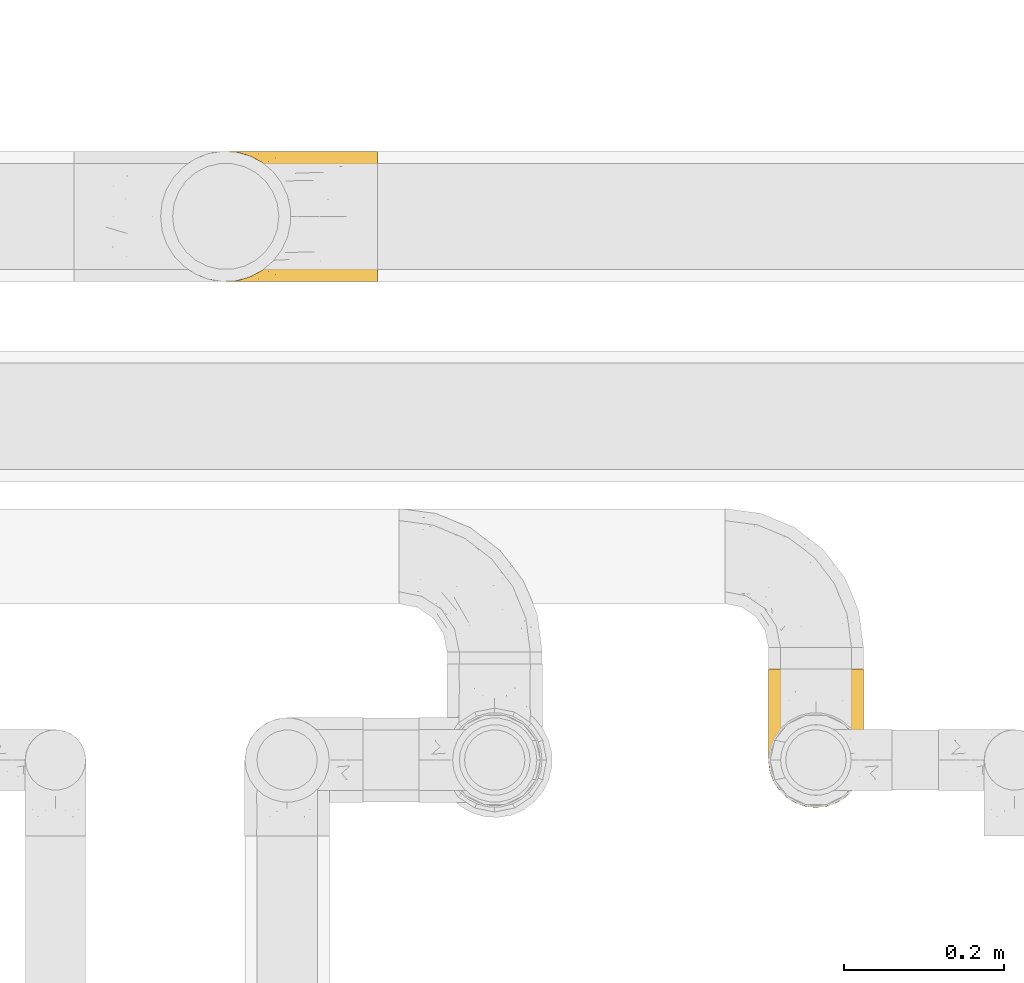
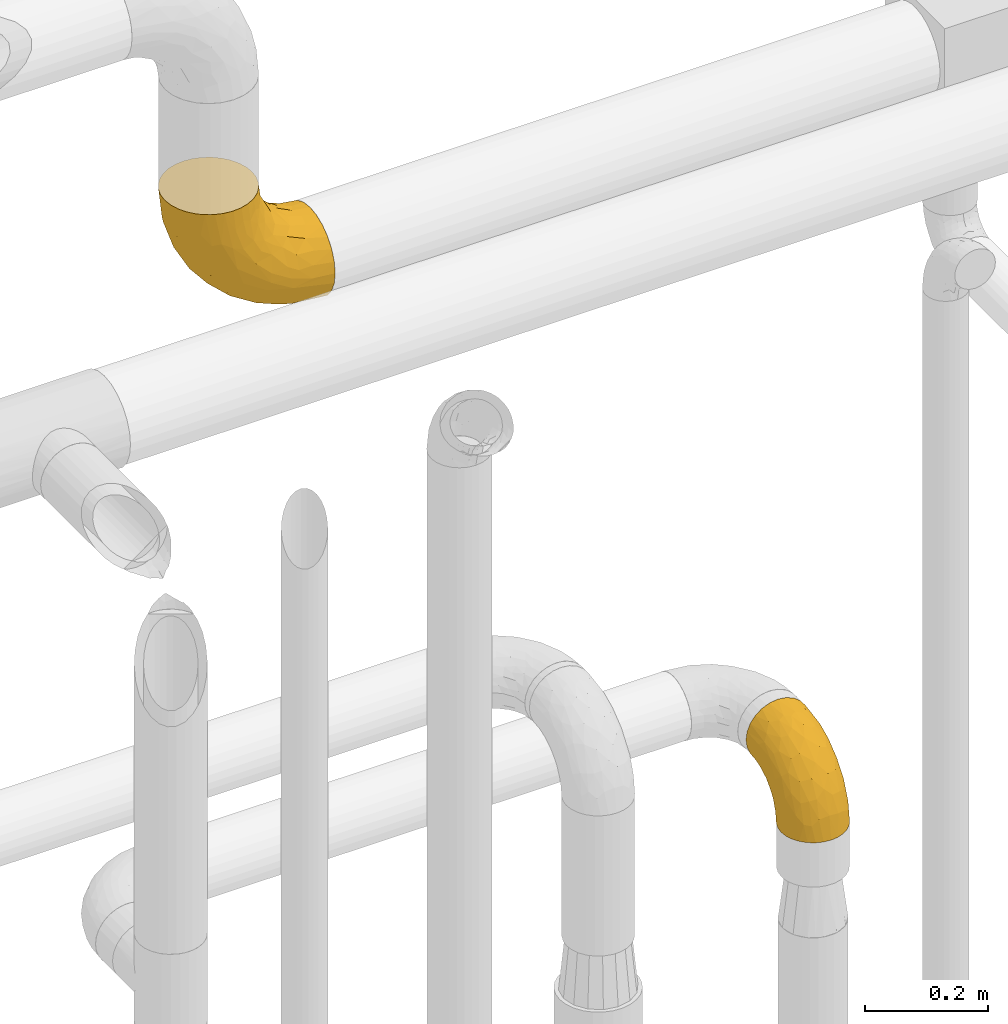
# One storey, part 474 of 827: 2 coverings.
"""IFC2X3 building model written with IfcOpenShell, lengths in millimetres."""

from ifc_helpers import new_model, entity, si_unit, converted_unit, derived_unit, direction, frame, origin, place, context, subcontext, project, spatial, faceted_brep, element, save


model = new_model("IFC2X3")

# Units and contexts
model_context = context("Model", 3, precision=0.01, world=origin(), true_north=direction((6.12303176911189e-17, 1.0)))
body_context = subcontext(model_context, "Body", "Model", "MODEL_VIEW")
ifc_project = project(units=[si_unit("LENGTHUNIT", "METRE", prefix="MILLI"), si_unit("AREAUNIT", "SQUARE_METRE"), si_unit("VOLUMEUNIT", "CUBIC_METRE"), converted_unit("PLANEANGLEUNIT", "DEGREE", entity("IfcRatioMeasure", 0.0174532925199433), si_unit("PLANEANGLEUNIT", "RADIAN"), dimensions=[0, 0, 0, 0, 0, 0, 0]), si_unit("MASSUNIT", "GRAM", prefix="KILO"), derived_unit("MASSDENSITYUNIT", [(si_unit("MASSUNIT", "GRAM", prefix="KILO"), 1), (si_unit("LENGTHUNIT", "METRE"), -3)]), derived_unit("MOMENTOFINERTIAUNIT", [(si_unit("LENGTHUNIT", "METRE"), 4)]), si_unit("TIMEUNIT", "SECOND"), si_unit("FREQUENCYUNIT", "HERTZ"), si_unit("THERMODYNAMICTEMPERATUREUNIT", "DEGREE_CELSIUS"), derived_unit("THERMALTRANSMITTANCEUNIT", [(si_unit("MASSUNIT", "GRAM", prefix="KILO"), 1), (si_unit("THERMODYNAMICTEMPERATUREUNIT", "KELVIN"), -1), (si_unit("TIMEUNIT", "SECOND"), -3)]), derived_unit("VOLUMETRICFLOWRATEUNIT", [(si_unit("LENGTHUNIT", "METRE"), 3), (si_unit("TIMEUNIT", "SECOND"), -1)]), derived_unit("MASSFLOWRATEUNIT", [(si_unit("MASSUNIT", "GRAM", prefix="KILO"), 1), (si_unit("TIMEUNIT", "SECOND"), -1)]), derived_unit("ROTATIONALFREQUENCYUNIT", [(si_unit("TIMEUNIT", "SECOND"), -1)]), si_unit("ELECTRICCURRENTUNIT", "AMPERE"), si_unit("ELECTRICVOLTAGEUNIT", "VOLT"), si_unit("POWERUNIT", "WATT"), si_unit("FORCEUNIT", "NEWTON", prefix="KILO"), si_unit("ILLUMINANCEUNIT", "LUX"), si_unit("LUMINOUSFLUXUNIT", "LUMEN"), si_unit("LUMINOUSINTENSITYUNIT", "CANDELA"), derived_unit("USERDEFINED", [(si_unit("MASSUNIT", "GRAM", prefix="KILO"), -1), (si_unit("LENGTHUNIT", "METRE"), -2), (si_unit("TIMEUNIT", "SECOND"), 3), (si_unit("LUMINOUSFLUXUNIT", "LUMEN"), 1)]), derived_unit("LINEARVELOCITYUNIT", [(si_unit("LENGTHUNIT", "METRE"), 1), (si_unit("TIMEUNIT", "SECOND"), -1)]), si_unit("PRESSUREUNIT", "PASCAL"), derived_unit("USERDEFINED", [(si_unit("LENGTHUNIT", "METRE"), -2), (si_unit("MASSUNIT", "GRAM", prefix="KILO"), 1), (si_unit("TIMEUNIT", "SECOND"), -2)]), derived_unit("LINEARFORCEUNIT", [(si_unit("MASSUNIT", "GRAM", prefix="KILO"), 1), (si_unit("LENGTHUNIT", "METRE"), 1), (si_unit("TIMEUNIT", "SECOND"), -2), (si_unit("LENGTHUNIT", "METRE"), -1)]), derived_unit("PLANARFORCEUNIT", [(si_unit("MASSUNIT", "GRAM", prefix="KILO"), 1), (si_unit("LENGTHUNIT", "METRE"), 1), (si_unit("TIMEUNIT", "SECOND"), -2), (si_unit("LENGTHUNIT", "METRE"), -2)])], contexts=[model_context])

# Site, building, storey
site_placement = place(None, origin())
site = spatial("IfcSite", under=ifc_project, at=site_placement, CompositionType="ELEMENT")
building_placement = place(site_placement, origin())
building = spatial("IfcBuilding", under=site, at=building_placement, CompositionType="ELEMENT")
storey_placement = place(building_placement, frame((0.0, 0.0, 28200.0)))
storey = spatial("IfcBuildingStorey", under=building, at=storey_placement, Name="08", CompositionType="ELEMENT", Elevation=28200.0)

# Coverings
covering_1_placement = place(storey_placement, frame((58588.34, 17438.95, 1984.4)))
element("IfcCovering", 1, at=covering_1_placement, inside=storey, Name=":ADSK_", ObjectType=":ADSK_", PredefinedType="INSULATION", context=body_context, shape_type="Brep", body=[
    faceted_brep([(119.0, 47.81, 1.6), (114.61, 35.25, 1.6), (107.52, 23.97, 1.6), (98.11, 14.56, 1.6), (86.83, 7.48, 1.6), (74.26, 3.08, 1.6), (61.05, 1.6, 1.6), (47.81, 3.09, 1.6), (35.25, 7.48, 1.6), (23.97, 14.57, 1.6), (14.56, 23.99, 1.6), (7.48, 35.26, 1.6), (3.08, 47.83, 1.6), (1.6, 61.05, 1.6), (3.09, 74.28, 1.6), (7.48, 86.84, 1.6), (14.57, 98.12, 1.6), (23.99, 107.53, 1.6), (35.26, 114.61, 1.6), (47.83, 119.01, 1.6), (61.05, 120.5, 1.6), (74.28, 119.0, 1.6), (86.84, 114.61, 1.6), (98.12, 107.52, 1.6), (107.53, 98.11, 1.6), (114.61, 86.83, 1.6), (119.01, 74.26, 1.6), (120.5, 61.05, 1.6), (45.66, 175.05, 58.17), (31.32, 175.05, 64.11), (19.01, 175.05, 73.56), (9.56, 175.05, 85.87), (3.62, 175.05, 100.21), (1.6, 175.05, 115.6), (3.62, 175.05, 130.98), (9.56, 175.05, 145.32), (19.01, 175.05, 157.63), (31.32, 175.05, 167.08), (45.66, 175.05, 173.02), (61.05, 175.05, 175.05), (76.43, 175.05, 173.02), (90.77, 175.05, 167.08), (103.08, 175.05, 157.63), (112.53, 175.05, 145.32), (118.47, 175.05, 130.98), (120.5, 175.05, 115.6), (118.47, 175.05, 100.21), (112.53, 175.05, 85.87), (103.08, 175.05, 73.56), (90.77, 175.05, 64.11), (76.43, 175.05, 58.17), (61.05, 175.05, 56.15), (95.74, 144.29, 160.93), (82.17, 133.4, 165.97), (93.88, 108.85, 151.16), (71.8, 137.58, 169.95), (61.05, 130.15, 169.14), (109.14, 33.43, 47.74), (108.65, 48.64, 81.62), (100.7, 32.13, 69.65), (79.94, 71.77, 137.09), (61.05, 88.32, 151.81), (61.05, 52.4, 124.24), (115.7, 105.93, 120.32), (112.92, 128.22, 136.76), (110.7, 102.42, 129.05), (117.93, 138.98, 127.83), (119.47, 114.96, 111.19), (89.21, 25.03, 73.49), (91.01, 14.44, 40.92), (83.0, 103.12, 154.8), (71.74, 109.71, 161.22), (106.1, 133.1, 148.51), (61.05, 7.51, 46.49), (79.17, 9.66, 43.55), (76.32, 38.78, 105.65), (73.8, 19.81, 75.81), (112.99, 73.56, 102.22), (104.29, 65.59, 111.05), (119.46, 53.66, 31.64), (119.47, 65.45, 61.68), (115.7, 56.32, 70.72), (120.5, 108.04, 93.82), (120.5, 123.93, 101.92), (120.5, 139.82, 110.02), (61.05, 24.83, 88.32), (115.97, 42.35, 34.61), (101.43, 20.84, 34.27), (94.14, 74.42, 130.32), (94.58, 46.21, 101.6), (104.07, 96.34, 135.16), (118.63, 83.99, 92.65), (120.5, 82.82, 68.6), (120.5, 95.43, 81.21), (120.5, 63.36, 16.21), (120.5, 66.62, 36.82), (120.5, 74.72, 52.71), (120.5, 160.43, 113.28), (117.67, 91.97, 49.51), (114.99, 88.98, 24.29), (109.18, 102.6, 33.37), (118.26, 155.55, 97.47), (117.87, 141.61, 92.13), (111.2, 123.71, 65.64), (103.41, 136.88, 63.0), (108.57, 141.73, 72.44), (112.76, 108.95, 54.52), (75.65, 132.33, 38.38), (89.98, 131.77, 46.09), (85.51, 122.46, 30.11), (61.05, 124.65, 22.47), (73.87, 123.29, 22.86), (111.26, 158.35, 82.06), (101.69, 153.2, 68.74), (88.74, 147.72, 56.57), (86.0, 162.85, 60.39), (74.52, 158.54, 55.21), (70.92, 144.02, 47.46), (61.05, 154.17, 51.99), (118.96, 76.05, 19.27), (119.01, 98.34, 66.98), (117.67, 113.97, 75.5), (82.93, 117.88, 15.03), (96.71, 111.71, 21.65), (96.25, 120.52, 38.96), (106.01, 101.36, 16.17), (119.26, 79.3, 36.61), (105.56, 112.64, 42.47), (61.05, 136.47, 40.17), (114.42, 138.23, 81.33), (119.14, 124.93, 89.72), (102.94, 123.97, 52.09), (18.7, 136.9, 62.98), (19.16, 123.98, 52.08), (10.9, 123.74, 65.65), (5.81, 148.89, 89.82), (2.95, 124.93, 89.72), (2.72, 138.07, 97.2), (46.46, 132.31, 38.35), (9.34, 108.96, 54.51), (1.6, 82.82, 68.6), (1.6, 95.43, 81.21), (3.08, 98.34, 66.99), (47.58, 158.54, 55.21), (7.11, 88.99, 24.29), (36.09, 162.86, 60.39), (16.09, 101.37, 16.17), (25.4, 111.72, 21.63), (3.83, 155.55, 97.47), (1.6, 160.43, 113.28), (4.42, 113.97, 75.5), (20.4, 153.21, 68.74), (51.15, 144.01, 47.46), (10.83, 158.35, 82.06), (16.53, 112.65, 42.47), (25.84, 120.51, 38.93), (48.24, 123.29, 22.84), (1.6, 66.62, 36.82), (1.6, 74.72, 52.71), (2.83, 79.32, 36.62), (1.6, 63.36, 16.21), (36.6, 122.45, 30.08), (39.17, 117.88, 15.02), (32.11, 131.76, 46.08), (33.35, 147.73, 56.57), (1.6, 123.93, 101.92), (4.42, 91.99, 49.52), (12.92, 102.61, 33.36), (3.14, 76.07, 19.28), (13.52, 141.72, 72.43), (1.6, 108.04, 93.82), (1.6, 139.82, 110.02), (7.67, 138.23, 81.33), (28.21, 108.85, 151.16), (26.35, 144.29, 160.93), (15.99, 133.1, 148.51), (9.17, 128.22, 136.76), (50.29, 137.58, 169.95), (39.92, 133.4, 165.97), (50.35, 109.71, 161.22), (2.62, 114.96, 111.19), (6.39, 56.32, 70.72), (2.63, 53.67, 31.66), (6.11, 42.36, 34.61), (17.8, 65.59, 111.05), (13.43, 48.62, 81.57), (27.5, 46.21, 101.58), (2.62, 65.45, 61.68), (3.46, 83.99, 92.65), (4.16, 138.98, 127.83), (39.09, 103.12, 154.8), (21.38, 32.14, 69.65), (20.65, 20.85, 34.27), (32.87, 25.03, 73.47), (31.06, 12.63, 32.52), (45.77, 38.78, 105.65), (42.15, 71.77, 137.09), (12.94, 33.44, 47.72), (11.39, 102.42, 129.05), (9.11, 73.52, 102.2), (42.91, 9.67, 43.54), (18.03, 96.34, 135.17), (27.95, 74.41, 130.32), (45.01, 20.85, 76.08), (6.39, 105.93, 120.32)], [[[0, 1, 2, 3, 4, 5, 6, 7, 8, 9, 10, 11, 12, 13, 14, 15, 16, 17, 18, 19, 20, 21, 22, 23, 24, 25, 26, 27]], [[28, 29, 30, 31, 32, 33, 34, 35, 36, 37, 38, 39, 40, 41, 42, 43, 44, 45, 46, 47, 48, 49, 50, 51]], [[52, 53, 54]], [[55, 39, 56]], [[57, 58, 59]], [[60, 61, 62]], [[63, 64, 65]], [[66, 63, 67]], [[59, 68, 69]], [[53, 70, 54]], [[41, 40, 53]], [[53, 71, 70]], [[72, 42, 52]], [[42, 41, 52]], [[73, 5, 74]], [[68, 75, 76]], [[43, 72, 64]], [[45, 44, 66]], [[58, 77, 78]], [[79, 80, 81]], [[67, 82, 83, 84]], [[75, 62, 85]], [[1, 0, 86]], [[2, 87, 3]], [[57, 87, 2]], [[42, 72, 43]], [[5, 4, 74]], [[2, 1, 57]], [[69, 3, 87]], [[5, 73, 6]], [[59, 87, 57]], [[66, 64, 63]], [[88, 89, 78]], [[54, 88, 90]], [[75, 60, 62]], [[91, 92, 93, 82]], [[79, 27, 94, 95]], [[76, 73, 74]], [[80, 95, 96, 92]], [[57, 1, 86]], [[56, 71, 55]], [[77, 91, 63]], [[80, 91, 81]], [[67, 91, 82]], [[71, 56, 61]], [[69, 4, 3]], [[74, 69, 68]], [[75, 89, 60]], [[80, 79, 95]], [[81, 57, 86]], [[76, 75, 85]], [[89, 68, 59]], [[58, 57, 81]], [[59, 58, 89]], [[90, 88, 78]], [[75, 68, 89]], [[70, 88, 54]], [[60, 89, 88]], [[77, 58, 81]], [[89, 58, 78]], [[91, 77, 81]], [[77, 63, 65]], [[78, 77, 65]], [[54, 90, 72]], [[91, 80, 92]], [[79, 81, 86]], [[86, 0, 79]], [[27, 79, 0]], [[66, 84, 97, 45]], [[91, 67, 63]], [[84, 66, 67]], [[64, 44, 43]], [[64, 66, 44]], [[65, 72, 90]], [[53, 52, 41]], [[72, 52, 54]], [[72, 65, 64]], [[65, 90, 78]], [[60, 71, 61]], [[55, 71, 53]], [[71, 60, 70]], [[88, 70, 60]], [[53, 40, 55]], [[39, 55, 40]], [[4, 69, 74]], [[59, 69, 87]], [[73, 76, 85]], [[68, 76, 74]], [[98, 99, 100]], [[84, 101, 97]], [[84, 83, 102]], [[97, 101, 46]], [[103, 104, 105]], [[47, 46, 101]], [[106, 98, 100]], [[107, 108, 109]], [[110, 107, 111]], [[112, 48, 47]], [[48, 113, 49]], [[113, 114, 115]], [[116, 51, 50]], [[115, 50, 49]], [[116, 117, 118]], [[119, 95, 94]], [[111, 107, 109]], [[93, 120, 121]], [[122, 123, 22]], [[121, 106, 103]], [[25, 24, 99]], [[114, 113, 104]], [[124, 109, 108]], [[25, 119, 26]], [[27, 26, 94]], [[112, 113, 48]], [[125, 123, 100]], [[24, 125, 99]], [[111, 20, 110]], [[109, 122, 111]], [[119, 94, 26]], [[99, 126, 119]], [[123, 124, 127]], [[117, 107, 128]], [[122, 22, 21]], [[129, 130, 121]], [[123, 23, 22]], [[92, 98, 120]], [[127, 106, 100]], [[23, 125, 24]], [[93, 121, 82]], [[119, 126, 95]], [[21, 20, 111]], [[123, 122, 109]], [[21, 111, 122]], [[107, 110, 128]], [[117, 128, 118]], [[107, 117, 108]], [[104, 108, 114]], [[124, 108, 131]], [[25, 99, 119]], [[96, 126, 98]], [[98, 92, 96]], [[123, 125, 23]], [[99, 125, 100]], [[103, 106, 131]], [[120, 106, 121]], [[83, 82, 130]], [[101, 102, 112]], [[130, 102, 83]], [[121, 130, 82]], [[102, 130, 129]], [[101, 112, 47]], [[112, 129, 105]], [[118, 51, 116]], [[108, 117, 114]], [[115, 116, 50]], [[114, 117, 116]], [[112, 102, 129]], [[102, 101, 84]], [[104, 103, 131]], [[129, 121, 103]], [[104, 131, 108]], [[105, 104, 113]], [[112, 105, 113]], [[103, 105, 129]], [[127, 124, 131]], [[123, 109, 124]], [[106, 127, 131]], [[123, 127, 100]], [[98, 126, 99]], [[95, 126, 96]], [[113, 115, 49]], [[116, 115, 114]], [[46, 45, 97]], [[92, 120, 93]], [[106, 120, 98]], [[132, 133, 134]], [[135, 136, 137]], [[110, 138, 128]], [[139, 134, 133]], [[140, 141, 142]], [[143, 51, 118]], [[16, 15, 144]], [[28, 145, 29]], [[146, 147, 17]], [[144, 146, 16]], [[31, 148, 32]], [[148, 149, 32]], [[139, 142, 150]], [[30, 29, 151]], [[152, 143, 118]], [[31, 30, 153]], [[139, 133, 154]], [[155, 154, 133]], [[110, 156, 138]], [[142, 141, 150]], [[20, 19, 156]], [[157, 158, 159]], [[14, 13, 160]], [[17, 16, 146]], [[161, 162, 147]], [[18, 162, 19]], [[152, 163, 164]], [[137, 136, 165]], [[144, 166, 167]], [[133, 163, 155]], [[144, 167, 146]], [[147, 18, 17]], [[29, 145, 151]], [[128, 138, 152]], [[160, 157, 168]], [[160, 168, 14]], [[14, 168, 15]], [[167, 166, 139]], [[151, 169, 153]], [[162, 156, 19]], [[141, 170, 150]], [[164, 163, 132]], [[147, 162, 18]], [[156, 162, 161]], [[156, 161, 138]], [[156, 110, 20]], [[163, 138, 161]], [[128, 152, 118]], [[155, 163, 161]], [[132, 163, 133]], [[159, 166, 144]], [[144, 15, 168]], [[166, 158, 140]], [[168, 159, 144]], [[147, 146, 167]], [[142, 139, 166]], [[134, 139, 150]], [[135, 31, 153]], [[136, 170, 165]], [[136, 150, 170]], [[148, 137, 171]], [[150, 136, 172]], [[151, 153, 30]], [[136, 135, 172]], [[163, 152, 138]], [[143, 28, 51]], [[152, 164, 143]], [[145, 143, 164]], [[171, 137, 165]], [[137, 148, 135]], [[31, 135, 148]], [[172, 135, 153]], [[150, 172, 134]], [[132, 169, 151]], [[169, 134, 172]], [[164, 132, 151]], [[134, 169, 132]], [[153, 169, 172]], [[161, 147, 155]], [[154, 147, 167]], [[147, 154, 155]], [[139, 154, 167]], [[157, 159, 168]], [[166, 159, 158]], [[143, 145, 28]], [[151, 145, 164]], [[149, 148, 171]], [[149, 33, 32]], [[140, 142, 166]], [[173, 174, 175]], [[35, 34, 176]], [[177, 178, 179]], [[180, 171, 165, 170]], [[181, 182, 183]], [[184, 185, 186]], [[187, 188, 140]], [[189, 33, 149, 171]], [[178, 190, 179]], [[34, 189, 176]], [[39, 38, 177]], [[191, 192, 193]], [[9, 8, 194]], [[174, 178, 37]], [[38, 37, 178]], [[35, 175, 36]], [[195, 62, 196]], [[180, 189, 171]], [[37, 36, 174]], [[183, 11, 197]], [[188, 170, 141, 140]], [[184, 198, 199]], [[8, 7, 200]], [[201, 184, 202]], [[13, 12, 182]], [[181, 185, 199]], [[183, 12, 11]], [[62, 195, 85]], [[202, 184, 186]], [[10, 197, 11]], [[199, 188, 181]], [[194, 8, 200]], [[203, 195, 193]], [[62, 61, 196]], [[197, 191, 185]], [[10, 192, 197]], [[7, 6, 73]], [[197, 192, 191]], [[192, 10, 9]], [[193, 192, 194]], [[7, 73, 200]], [[179, 61, 56]], [[203, 73, 85]], [[187, 140, 158, 157]], [[180, 188, 204]], [[179, 196, 61]], [[197, 181, 183]], [[181, 187, 182]], [[201, 173, 175]], [[203, 193, 200]], [[186, 191, 193]], [[197, 185, 181]], [[193, 195, 186]], [[196, 186, 195]], [[186, 196, 202]], [[190, 202, 196]], [[186, 185, 191]], [[199, 185, 184]], [[198, 184, 201]], [[188, 199, 204]], [[173, 201, 202]], [[175, 176, 198]], [[188, 180, 170]], [[189, 180, 204]], [[189, 204, 176]], [[189, 34, 33]], [[187, 157, 182]], [[188, 187, 181]], [[182, 157, 160, 13]], [[12, 183, 182]], [[198, 176, 204]], [[35, 176, 175]], [[175, 174, 36]], [[178, 174, 173]], [[199, 198, 204]], [[175, 198, 201]], [[177, 179, 56]], [[178, 173, 190]], [[202, 190, 173]], [[196, 179, 190]], [[39, 177, 56]], [[38, 178, 177]], [[193, 194, 200]], [[9, 194, 192]], [[73, 203, 200]], [[85, 195, 203]]]),
])
covering_2_placement = place(storey_placement, frame((57827.95, 18097.0, 2816.9)))
element("IfcCovering", 2, at=covering_2_placement, inside=storey, Name=":ADSK_", ObjectType=":ADSK_", PredefinedType="INSULATION", context=body_context, shape_type="Brep", body=[
    faceted_brep([(51.91, 158.39, 273.1), (37.82, 150.86, 273.1), (25.47, 140.72, 273.1), (15.33, 128.37, 273.1), (7.8, 114.28, 273.1), (3.16, 98.99, 273.1), (1.6, 83.1, 273.1), (3.16, 67.2, 273.1), (7.8, 51.91, 273.1), (15.33, 37.82, 273.1), (25.47, 25.47, 273.1), (37.82, 15.33, 273.1), (51.91, 7.8, 273.1), (67.2, 3.16, 273.1), (83.1, 1.6, 273.1), (99.0, 3.16, 273.1), (114.28, 7.8, 273.1), (128.37, 15.33, 273.1), (140.72, 25.47, 273.1), (150.86, 37.82, 273.1), (158.39, 51.91, 273.1), (163.03, 67.2, 273.1), (164.6, 83.1, 273.1), (163.03, 99.0, 273.1), (158.39, 114.28, 273.1), (150.86, 128.37, 273.1), (140.72, 140.72, 273.1), (128.37, 150.86, 273.1), (114.28, 158.39, 273.1), (98.99, 163.03, 273.1), (83.1, 164.6, 273.1), (67.2, 163.03, 273.1), (273.1, 62.0, 161.82), (273.1, 42.35, 153.68), (273.1, 25.47, 140.72), (273.1, 12.51, 123.85), (273.1, 4.37, 104.19), (273.1, 1.6, 83.1), (273.1, 4.37, 62.0), (273.1, 12.51, 42.35), (273.1, 25.47, 25.47), (273.1, 42.35, 12.51), (273.1, 62.0, 4.37), (273.1, 83.1, 1.6), (273.1, 104.19, 4.37), (273.1, 123.85, 12.51), (273.1, 140.72, 25.47), (273.1, 153.68, 42.35), (273.1, 161.82, 62.0), (273.1, 164.6, 83.1), (273.1, 161.82, 104.19), (273.1, 153.68, 123.85), (273.1, 140.72, 140.72), (273.1, 123.85, 153.68), (273.1, 104.19, 161.82), (273.1, 83.1, 164.6), (197.18, 104.67, 15.45), (220.13, 83.1, 6.81), (169.2, 83.1, 22.26), (165.22, 132.71, 42.42), (112.74, 128.57, 71.44), (136.63, 140.31, 65.97), (69.59, 127.0, 113.44), (106.1, 111.93, 65.75), (65.75, 107.33, 103.59), (101.73, 96.47, 63.94), (47.92, 153.13, 218.6), (151.7, 119.3, 39.77), (143.42, 101.32, 36.91), (67.74, 142.92, 138.84), (44.25, 142.61, 183.71), (64.23, 151.87, 168.19), (221.53, 162.56, 71.48), (190.66, 164.6, 101.91), (230.82, 164.6, 87.86), (122.26, 83.1, 47.35), (31.44, 117.97, 167.63), (17.25, 119.64, 212.84), (37.36, 131.15, 173.72), (81.12, 83.1, 81.12), (47.35, 83.1, 122.26), (210.98, 156.52, 56.45), (181.7, 144.21, 46.95), (232.28, 146.25, 35.05), (211.28, 130.43, 24.32), (87.86, 164.6, 230.82), (79.61, 162.51, 195.92), (152.2, 159.97, 92.81), (136.41, 151.26, 82.34), (92.77, 151.21, 122.78), (226.05, 117.68, 13.53), (89.58, 158.25, 149.02), (104.94, 163.04, 154.38), (11.64, 105.24, 212.27), (28.2, 100.78, 160.47), (33.2, 144.52, 230.92), (98.82, 141.87, 98.82), (24.35, 132.77, 218.75), (22.26, 83.1, 169.2), (6.81, 83.1, 220.13), (101.91, 164.6, 190.66), (124.55, 164.6, 154.63), (154.63, 164.6, 124.55), (242.08, 151.23, 131.16), (231.65, 137.69, 150.42), (233.63, 161.34, 110.62), (155.43, 141.27, 211.28), (146.77, 138.72, 240.6), (162.22, 127.05, 223.71), (184.19, 109.71, 203.39), (169.91, 83.1, 239.57), (185.32, 83.1, 209.32), (213.9, 120.43, 171.53), (197.8, 138.75, 166.55), (180.95, 129.2, 191.93), (136.57, 161.91, 173.04), (123.35, 161.43, 198.01), (145.64, 155.97, 187.52), (185.45, 162.57, 125.16), (157.77, 160.03, 157.77), (182.66, 151.82, 158.24), (245.12, 117.14, 160.57), (164.57, 109.48, 242.02), (133.28, 148.92, 248.61), (136.47, 151.93, 220.59), (206.49, 154.85, 137.18), (248.1, 98.92, 165.92), (222.02, 100.98, 175.12), (209.32, 83.1, 185.32), (239.57, 83.1, 169.91), (167.88, 145.5, 184.45), (118.7, 158.16, 238.32), (108.44, 162.97, 217.41), (102.71, 162.71, 245.77), (200.15, 98.76, 190.73), (211.84, 160.15, 121.56), (155.81, 124.12, 249.77), (162.83, 154.06, 171.52), (206.49, 11.34, 137.18), (231.65, 28.5, 150.42), (197.8, 27.44, 166.55), (182.66, 14.37, 158.24), (248.1, 67.27, 165.92), (222.02, 65.22, 175.12), (162.22, 39.14, 223.71), (155.43, 24.93, 211.28), (180.95, 36.99, 191.92), (102.71, 3.48, 245.77), (184.19, 56.48, 203.4), (242.08, 14.96, 131.16), (233.63, 4.85, 110.62), (155.81, 42.07, 249.77), (146.78, 27.47, 240.6), (213.9, 45.76, 171.53), (200.15, 67.43, 190.73), (108.44, 3.22, 217.41), (118.7, 8.03, 238.31), (230.82, 1.6, 87.86), (245.12, 49.05, 160.57), (133.28, 17.27, 248.61), (164.57, 56.71, 242.02), (206.34, 3.08, 111.86), (185.45, 3.62, 125.16), (101.91, 1.6, 190.66), (124.55, 1.6, 154.63), (123.35, 4.76, 198.01), (154.63, 1.6, 124.55), (190.66, 1.6, 101.91), (167.88, 20.69, 184.45), (157.77, 6.16, 157.77), (136.47, 14.26, 220.59), (145.64, 10.22, 187.52), (136.57, 4.28, 173.04), (87.86, 1.6, 230.82), (162.96, 12.35, 171.95), (211.28, 35.76, 24.32), (44.25, 23.58, 183.71), (37.35, 35.03, 173.75), (59.81, 34.03, 133.19), (14.04, 46.35, 229.24), (195.92, 3.68, 79.61), (154.38, 3.15, 104.94), (149.02, 7.94, 89.58), (98.82, 24.32, 98.82), (94.45, 41.48, 84.08), (92.81, 6.22, 152.2), (82.48, 2.91, 198.75), (108.3, 57.48, 62.55), (198.33, 10.43, 58.85), (169.99, 33.0, 40.65), (181.7, 21.98, 46.95), (135.99, 28.1, 63.87), (192.96, 47.91, 22.06), (33.21, 21.67, 230.92), (65.75, 58.86, 103.59), (49.37, 13.93, 207.65), (151.7, 46.89, 39.77), (148.6, 62.93, 34.68), (232.28, 19.94, 35.05), (197.18, 61.52, 15.45), (72.78, 15.08, 150.41), (63.87, 6.68, 210.73), (28.2, 65.41, 160.46), (136.17, 16.65, 79.42), (107.34, 11.53, 115.1), (11.64, 60.95, 212.26), (24.35, 33.42, 218.75), (31.44, 48.22, 167.63)], [[[0, 1, 2, 3, 4, 5, 6, 7, 8, 9, 10, 11, 12, 13, 14, 15, 16, 17, 18, 19, 20, 21, 22, 23, 24, 25, 26, 27, 28, 29, 30, 31]], [[32, 33, 34, 35, 36, 37, 38, 39, 40, 41, 42, 43, 44, 45, 46, 47, 48, 49, 50, 51, 52, 53, 54, 55]], [[56, 57, 58]], [[57, 44, 43]], [[59, 60, 61]], [[62, 63, 64]], [[63, 65, 64]], [[1, 0, 66]], [[67, 68, 63]], [[69, 70, 71]], [[72, 73, 74]], [[75, 68, 58]], [[76, 77, 78]], [[64, 79, 80]], [[81, 48, 47]], [[82, 83, 84]], [[31, 85, 86]], [[71, 70, 66]], [[47, 83, 81]], [[87, 88, 89]], [[69, 62, 78]], [[49, 48, 72]], [[90, 44, 56]], [[48, 81, 72]], [[87, 91, 92]], [[93, 76, 94]], [[70, 95, 66]], [[88, 96, 89]], [[45, 84, 46]], [[2, 95, 97]], [[4, 93, 5]], [[98, 99, 93]], [[59, 84, 67]], [[3, 97, 77]], [[71, 86, 91]], [[4, 3, 77]], [[90, 84, 45]], [[99, 6, 5]], [[83, 47, 46]], [[95, 2, 1]], [[94, 80, 98]], [[100, 101, 92]], [[66, 31, 86]], [[60, 63, 62]], [[85, 31, 30]], [[102, 87, 92]], [[93, 77, 76]], [[91, 86, 92]], [[44, 57, 56]], [[86, 85, 100]], [[78, 97, 70]], [[87, 102, 73]], [[2, 97, 3]], [[67, 84, 90]], [[31, 66, 0]], [[93, 94, 98]], [[88, 81, 82]], [[99, 5, 93]], [[87, 73, 72]], [[66, 95, 1]], [[97, 95, 70]], [[86, 71, 66]], [[69, 89, 96]], [[89, 71, 91]], [[69, 96, 62]], [[60, 62, 96]], [[76, 62, 64]], [[71, 89, 69]], [[87, 89, 91]], [[81, 88, 87]], [[61, 88, 82]], [[61, 60, 96]], [[60, 67, 63]], [[68, 67, 56]], [[79, 65, 75]], [[58, 68, 56]], [[65, 68, 75]], [[64, 65, 79]], [[68, 65, 63]], [[76, 64, 94]], [[80, 94, 64]], [[100, 92, 86]], [[92, 101, 102]], [[88, 61, 96]], [[59, 61, 82]], [[84, 59, 82]], [[60, 59, 67]], [[87, 72, 81]], [[49, 72, 74]], [[84, 83, 46]], [[81, 83, 82]], [[69, 78, 70]], [[62, 76, 78]], [[4, 77, 93]], [[78, 77, 97]], [[44, 90, 45]], [[67, 90, 56]], [[103, 104, 52]], [[50, 49, 74]], [[50, 74, 105]], [[106, 107, 108]], [[109, 110, 111]], [[112, 113, 114]], [[104, 113, 112]], [[73, 105, 74]], [[115, 116, 117]], [[118, 119, 120]], [[104, 53, 52]], [[51, 103, 52]], [[53, 121, 54]], [[24, 23, 122]], [[123, 107, 124]], [[122, 109, 108]], [[125, 120, 113]], [[55, 54, 126]], [[102, 118, 73]], [[127, 126, 121]], [[128, 129, 127]], [[105, 51, 50]], [[102, 101, 119]], [[120, 130, 113]], [[26, 123, 27]], [[27, 131, 28]], [[132, 85, 133]], [[85, 29, 133]], [[134, 111, 128]], [[28, 133, 29]], [[30, 29, 85]], [[116, 131, 124]], [[135, 73, 118]], [[27, 123, 131]], [[110, 23, 22]], [[136, 122, 108]], [[24, 136, 25]], [[114, 108, 109]], [[119, 115, 117]], [[136, 107, 25]], [[128, 127, 134]], [[122, 110, 109]], [[104, 112, 121]], [[107, 106, 124]], [[107, 26, 25]], [[23, 110, 122]], [[101, 100, 116]], [[131, 132, 133]], [[105, 135, 103]], [[116, 124, 117]], [[122, 136, 24]], [[107, 136, 108]], [[28, 131, 133]], [[131, 116, 132]], [[126, 127, 129]], [[134, 112, 109]], [[107, 123, 26]], [[131, 123, 124]], [[104, 121, 53]], [[127, 121, 112]], [[105, 103, 51]], [[104, 103, 125]], [[116, 100, 132]], [[85, 132, 100]], [[106, 117, 124]], [[137, 130, 120]], [[114, 106, 108]], [[106, 130, 117]], [[119, 118, 102]], [[135, 118, 125]], [[125, 113, 104]], [[114, 113, 130]], [[114, 130, 106]], [[112, 114, 109]], [[118, 120, 125]], [[117, 137, 119]], [[55, 126, 129]], [[121, 126, 54]], [[112, 134, 127]], [[111, 134, 109]], [[119, 101, 115]], [[101, 116, 115]], [[103, 135, 125]], [[73, 135, 105]], [[130, 137, 117]], [[120, 119, 137]], [[138, 139, 140]], [[140, 141, 138]], [[55, 129, 142]], [[143, 142, 129]], [[144, 145, 146]], [[147, 16, 15]], [[110, 148, 111]], [[128, 143, 129]], [[149, 150, 35]], [[151, 152, 144]], [[153, 143, 154]], [[147, 155, 156]], [[35, 150, 36]], [[37, 36, 157]], [[35, 34, 149]], [[139, 33, 158]], [[159, 152, 18]], [[150, 157, 36]], [[140, 139, 153]], [[139, 34, 33]], [[110, 21, 160]], [[150, 161, 157]], [[20, 19, 151]], [[161, 138, 162]], [[110, 22, 21]], [[163, 164, 165]], [[166, 167, 162]], [[151, 160, 20]], [[140, 146, 168]], [[111, 148, 154]], [[164, 166, 169]], [[18, 152, 19]], [[170, 156, 165]], [[17, 159, 18]], [[158, 33, 32]], [[171, 165, 172]], [[155, 165, 156]], [[148, 110, 160]], [[170, 159, 156]], [[160, 144, 148]], [[15, 14, 173]], [[170, 171, 145]], [[149, 139, 138]], [[15, 173, 147]], [[144, 152, 145]], [[156, 17, 16]], [[165, 171, 170]], [[20, 160, 21]], [[171, 172, 169]], [[169, 166, 162]], [[152, 151, 19]], [[160, 151, 144]], [[155, 173, 163]], [[156, 16, 147]], [[154, 143, 128]], [[143, 153, 158]], [[156, 159, 17]], [[152, 159, 170]], [[158, 32, 142]], [[139, 158, 153]], [[139, 149, 34]], [[150, 149, 138]], [[173, 155, 147]], [[163, 165, 155]], [[174, 169, 141]], [[145, 171, 168]], [[170, 145, 152]], [[146, 145, 168]], [[161, 162, 167]], [[162, 138, 141]], [[146, 153, 148]], [[140, 168, 141]], [[153, 146, 140]], [[144, 146, 148]], [[174, 141, 168]], [[162, 141, 169]], [[158, 142, 143]], [[55, 142, 32]], [[111, 154, 128]], [[153, 154, 148]], [[165, 164, 172]], [[164, 169, 172]], [[157, 161, 167]], [[138, 161, 150]], [[168, 171, 174]], [[169, 174, 171]], [[41, 40, 175]], [[176, 177, 178]], [[9, 8, 179]], [[180, 181, 182]], [[157, 180, 37]], [[183, 178, 184]], [[164, 185, 181]], [[13, 186, 173]], [[187, 79, 75]], [[167, 166, 181]], [[186, 163, 173]], [[182, 188, 180]], [[57, 43, 42]], [[189, 190, 191]], [[164, 186, 185]], [[192, 41, 175]], [[193, 11, 10]], [[178, 194, 184]], [[12, 11, 195]], [[196, 187, 197]], [[40, 198, 175]], [[198, 40, 39]], [[58, 199, 197]], [[200, 185, 201]], [[163, 186, 164]], [[201, 185, 186]], [[202, 80, 194]], [[190, 203, 191]], [[201, 186, 13]], [[204, 185, 200]], [[201, 13, 12]], [[41, 199, 42]], [[195, 200, 201]], [[98, 205, 99]], [[57, 42, 199]], [[13, 173, 14]], [[58, 57, 199]], [[193, 206, 176]], [[80, 79, 194]], [[207, 205, 202]], [[196, 184, 187]], [[202, 205, 98]], [[205, 179, 8]], [[9, 206, 10]], [[207, 206, 179]], [[182, 203, 188]], [[6, 99, 7]], [[188, 38, 180]], [[203, 182, 204]], [[7, 205, 8]], [[37, 180, 38]], [[167, 180, 157]], [[7, 99, 205]], [[182, 181, 185]], [[11, 193, 195]], [[196, 191, 184]], [[175, 189, 192]], [[198, 188, 190]], [[38, 188, 39]], [[206, 193, 10]], [[195, 193, 176]], [[195, 176, 200]], [[12, 195, 201]], [[178, 200, 176]], [[185, 204, 182]], [[200, 183, 204]], [[203, 204, 183]], [[191, 203, 183]], [[188, 203, 190]], [[184, 191, 183]], [[190, 189, 175]], [[200, 178, 183]], [[184, 194, 187]], [[177, 176, 206]], [[194, 178, 207]], [[79, 187, 194]], [[197, 199, 192]], [[187, 75, 197]], [[58, 197, 75]], [[191, 196, 189]], [[192, 189, 196]], [[80, 202, 98]], [[194, 207, 202]], [[167, 181, 180]], [[181, 166, 164]], [[188, 198, 39]], [[175, 198, 190]], [[207, 179, 205]], [[9, 179, 206]], [[197, 192, 196]], [[41, 192, 199]], [[206, 207, 177]], [[207, 178, 177]]]),
])

save(model, "model.ifc")
